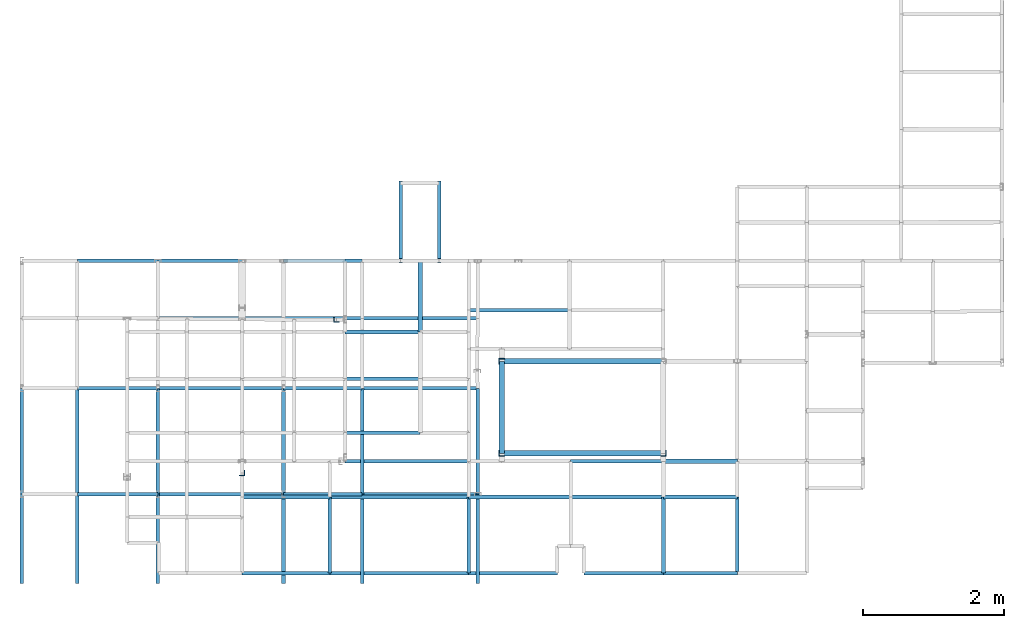
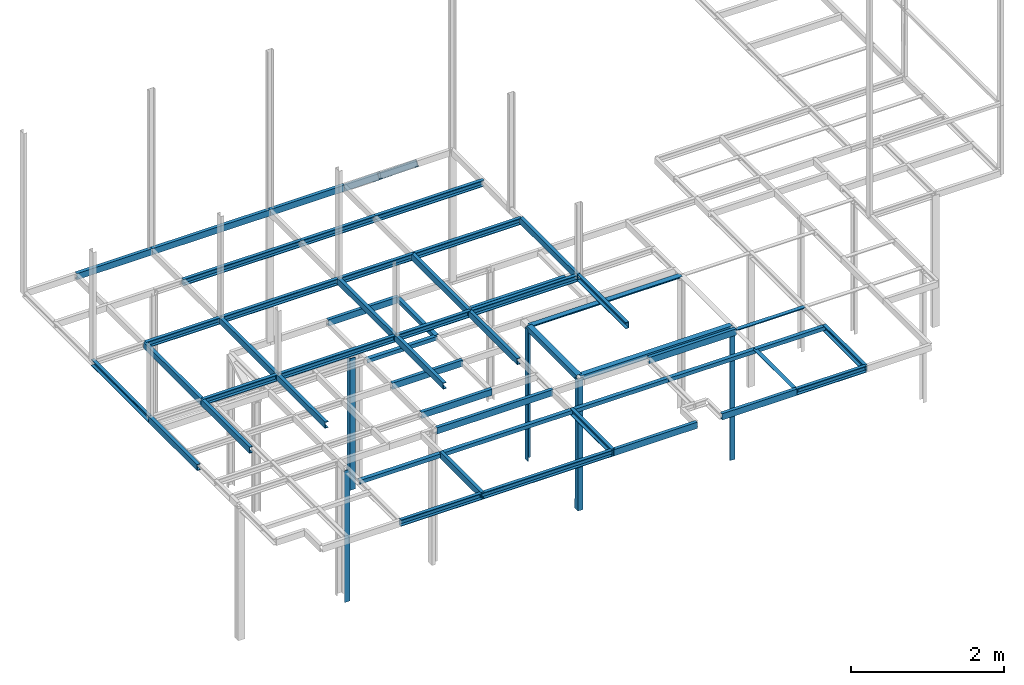
# Not in any storey, part 3 of 7: 52 beams, 7 members.
"""IFC2X3 model written with IfcOpenShell, lengths in centimetres."""

from ifc_helpers import new_model, si_unit, frame, frame_2d, origin_with_axes, origin_2d_with_axis, place, context, project, polyline, l_section, u_section, outline, extrude, material, element, save


model = new_model("IFC2X3")

# Units and contexts
model_context = context("Model", 3, precision=1e-05, world=origin_with_axes())
plan_context = context("Plan", 3, precision=1e-05, world=origin_with_axes())
ifc_project = project(units=[si_unit("LENGTHUNIT", "METRE", prefix="CENTI"), si_unit("AREAUNIT", "SQUARE_METRE", prefix="CENTI"), si_unit("VOLUMEUNIT", "CUBIC_METRE", prefix="CENTI"), si_unit("PLANEANGLEUNIT", "RADIAN"), si_unit("SOLIDANGLEUNIT", "STERADIAN"), si_unit("MASSUNIT", "GRAM"), si_unit("TIMEUNIT", "SECOND"), si_unit("THERMODYNAMICTEMPERATUREUNIT", "DEGREE_CELSIUS"), si_unit("LUMINOUSINTENSITYUNIT", "LUMEN")], contexts=[model_context, plan_context])

# Members
ifc_material = material()
for number, where, z_axis, x_axis in (
    (1, (-455.200012207031, 191.800003051758, 0.0), (0.0, 0.0, 1.0), (1.0, 0.0, 0.0)),
    (2, (-221.0, 132.699996948242, 0.0), (0.0, 0.0, 1.0), (0.0, -1.0, 0.0)),
):
    element("IfcMember", number, at=place(None, frame(where, z_axis=z_axis, x_axis=x_axis)), material=ifc_material, context=model_context, shape_type="SweptSolid", body=[
        extrude(l_section(Depth=8.0, Width=8.0, Thickness=0.8, FilletRadius=1.0, EdgeRadius=0.0, LegSlope=0.0, CentreOfGravityInX=0.0, CentreOfGravityInY=0.0, at=origin_2d_with_axis()), origin_with_axes(), (0.0, 0.0, 1.0), 210.0),
    ])
member_1_placement = place(None, frame((-221.199996948242, 2.299999952316, 0.0), z_axis=(0.000952365988, 0.0, 0.999999546499), x_axis=(0.999999523163, 0.0, -0.000952365983)))
element("IfcMember", 3, at=member_1_placement, material=ifc_material, context=model_context, shape_type="SweptSolid", body=[
    extrude(l_section(Depth=8.0, Width=8.0, Thickness=0.8, FilletRadius=1.0, EdgeRadius=0.0, LegSlope=0.0, CentreOfGravityInX=0.0, CentreOfGravityInY=0.0, at=frame_2d((0.0, -1.19209e-07), x_axis=(1.0, 0.0))), origin_with_axes(), (0.0, 0.0, 1.0), 210.000095235167),
])
member_2_placement = place(None, frame((8.199999809265, 2.299999952316, 0.0), z_axis=(0.0, 0.0, 1.0), x_axis=(0.0, 1.0, 0.0)))
element("IfcMember", 4, at=member_2_placement, material=ifc_material, context=model_context, shape_type="SweptSolid", body=[
    extrude(l_section(Depth=8.0, Width=8.0, Thickness=0.8, FilletRadius=1.0, EdgeRadius=0.0, LegSlope=0.0, CentreOfGravityInX=0.0, CentreOfGravityInY=0.0, at=frame_2d((-3.57628e-07, -2.38419e-07), x_axis=(1.0, 0.0))), origin_with_axes(), (0.0, 0.0, 1.0), 210.0),
])
member_3_placement = place(None, frame((-589.100036621094, -25.700000762939, 0.0), z_axis=(0.0, 0.0, 1.0), x_axis=(0.0, 1.0, 0.0)))
element("IfcMember", 5, at=member_3_placement, material=ifc_material, context=model_context, shape_type="SweptSolid", body=[
    extrude(l_section(Depth=8.0, Width=8.0, Thickness=0.8, FilletRadius=1.0, EdgeRadius=0.0, LegSlope=0.0, CentreOfGravityInX=0.0, CentreOfGravityInY=0.0, at=origin_2d_with_axis()), origin_with_axes(), (0.0, 0.0, 1.0), 210.0),
])

# Beams
beam_1_placement = place(None, frame((-336.600006103516, 275.0, 210.0), z_axis=(-1.0, 0.0, 0.0), x_axis=(0.0, 1.0, 0.0)))
element("IfcBeam", 6, at=beam_1_placement, material=ifc_material, Name="UPN - de ala UPN 100", context=model_context, shape_type="SweptSolid", body=[
    extrude(u_section(Depth=10.0, FlangeWidth=5.0, WebThickness=0.6, FlangeThickness=0.85, FilletRadius=0.0, EdgeRadius=0.0, FlangeSlope=0.0, CentreOfGravityInX=0.0, at=origin_2d_with_axis()), origin_with_axes(), (0.0, 0.0, 1.0), 106.5),
])
beam_2_placement = place(None, frame((-336.600006103516, 174.400009155273, 210.0), z_axis=(0.0, 1.0, 0.0), x_axis=(-1.0, 0.0, 0.0)))
element("IfcBeam", 7, at=beam_2_placement, material=ifc_material, context=model_context, shape_type="SweptSolid", body=[
    extrude(outline(polyline([(3.0, -3.0), (3.0, 3.0), (-3.0, 3.0), (-3.0, 2.5), (2.5, 2.5), (2.5, -3.0), (3.0, -3.0)])), origin_with_axes(), (0.0, 0.0, 1.0), 100.599990844727),
])
beam_3_placement = place(None, frame((-124.899993896484, 205.199996948242, 210.0), z_axis=(-1.0, 0.0, 0.0), x_axis=(0.0, 1.0, 0.0)))
element("IfcBeam", 8, at=beam_3_placement, material=ifc_material, Name="UPN - de ala UPN 100", context=model_context, shape_type="SweptSolid", body=[
    extrude(u_section(Depth=10.0, FlangeWidth=5.0, WebThickness=0.6, FlangeThickness=0.85, FilletRadius=0.0, EdgeRadius=0.0, FlangeSlope=0.0, CentreOfGravityInX=0.0, at=origin_2d_with_axis()), origin_with_axes(), (0.0, 0.0, 1.0), 143.100006103516),
])
beam_4_placement = place(None, frame((-336.600006103516, 174.400009155273, 210.0), z_axis=(-1.0, 0.0, 0.0), x_axis=(0.0, -1.0, 0.0)))
element("IfcBeam", 9, at=beam_4_placement, material=ifc_material, context=model_context, shape_type="SweptSolid", body=[
    extrude(outline(polyline([(3.0, -3.0), (3.0, 3.0), (-3.0, 3.0), (-3.0, 2.5), (2.5, 2.5), (2.5, -3.0), (3.0, -3.0)])), origin_with_axes(), (0.0, 0.0, 1.0), 106.5),
])
beam_5_placement = place(None, frame((8.199996948242, 132.699996948242, 210.0), z_axis=(-1.0, 0.0, 0.0), x_axis=(0.0, 0.0, 1.0)))
element("IfcBeam", 10, at=beam_5_placement, material=ifc_material, context=model_context, shape_type="SweptSolid", body=[
    extrude(outline(polyline([(4.0, -4.0), (4.0, 4.0), (-4.0, 4.0), (-4.0, 3.199996948242), (3.199996948242, 3.199996948242), (3.199996948242, -4.0), (4.0, -4.0)])), origin_with_axes(), (0.0, 0.0, 1.0), 229.199996948242),
])
beam_6_placement = place(None, frame((-221.0, 2.300003051758, 210.0), z_axis=(0.0, 1.0, 0.0), x_axis=(-1.0, 0.0, 0.0)))
element("IfcBeam", 11, at=beam_6_placement, material=ifc_material, context=model_context, shape_type="SweptSolid", body=[
    extrude(outline(polyline([(4.0, -4.0), (4.0, 4.0), (-4.0, 4.0), (-4.0, 3.199996948242), (3.199996948242, 3.199996948242), (3.199996948242, -4.0), (4.0, -4.0)])), origin_with_axes(), (0.0, 0.0, 1.0), 130.399993896484),
])
beam_7_placement = place(None, frame((-336.600006103516, 108.200004577637, 210.0), z_axis=(-1.0, 0.0, 0.0), x_axis=(0.0, 1.0, 0.0)))
element("IfcBeam", 12, at=beam_7_placement, material=ifc_material, Name="UPN - de ala UPN 100", context=model_context, shape_type="SweptSolid", body=[
    extrude(u_section(Depth=10.0, FlangeWidth=5.0, WebThickness=0.6, FlangeThickness=0.85, FilletRadius=0.0, EdgeRadius=0.0, FlangeSlope=0.0, CentreOfGravityInX=0.0, at=origin_2d_with_axis()), origin_with_axes(), (0.0, 0.0, 1.0), 106.5),
])
beam_8_placement = place(None, frame((-336.600006103516, 31.60000038147, 210.0), z_axis=(-1.0, 0.0, 0.0), x_axis=(0.0, 1.0, 0.0)))
element("IfcBeam", 13, at=beam_8_placement, material=ifc_material, Name="UPN - de ala UPN 100", context=model_context, shape_type="SweptSolid", body=[
    extrude(u_section(Depth=10.0, FlangeWidth=5.0, WebThickness=0.6, FlangeThickness=0.85, FilletRadius=0.0, EdgeRadius=0.0, FlangeSlope=0.0, CentreOfGravityInX=0.0, at=frame_2d((9.53674e-07, 0.0), x_axis=(1.0, 0.0))), origin_with_axes(), (0.0, 0.0, 1.0), 106.5),
])
beam_9_placement = place(None, frame((8.199996948242, 2.299999952316, 210.0), z_axis=(-1.0, 0.0, 0.0), x_axis=(0.0, -1.0, 0.0)))
element("IfcBeam", 14, at=beam_9_placement, material=ifc_material, context=model_context, shape_type="SweptSolid", body=[
    extrude(outline(polyline([(4.000000476837, -4.0), (3.999999284744, 4.0), (-4.000000238419, 4.0), (-4.000000238419, 3.199996948242), (3.199999570847, 3.199996948242), (3.200000762939, -4.0), (4.000000476837, -4.0)])), origin_with_axes(), (0.0, 0.0, 1.0), 229.199996948242),
])
beam_10_placement = place(None, frame((-268.0, -9.0, 210.0), z_axis=(-1.0, 0.0, 0.0), x_axis=(0.0, 1.0, 0.0)))
element("IfcBeam", 15, at=beam_10_placement, material=ifc_material, Name="UPN - de ala UPN 100", context=model_context, shape_type="SweptSolid", body=[
    extrude(u_section(Depth=10.0, FlangeWidth=5.0, WebThickness=0.6, FlangeThickness=0.85, FilletRadius=0.0, EdgeRadius=0.0, FlangeSlope=0.0, CentreOfGravityInX=0.0, at=frame_2d((2.38419e-07, 0.0), x_axis=(1.0, 0.0))), origin_with_axes(), (0.0, 0.0, 1.0), 175.0),
])
beam_11_placement = place(None, frame((8.199996948242, -9.0, 210.0), z_axis=(-1.0, 0.0, 0.0), x_axis=(0.0, 1.0, 0.0)))
element("IfcBeam", 16, at=beam_11_placement, material=ifc_material, Name="UPN - de ala UPN 100", context=model_context, shape_type="SweptSolid", body=[
    extrude(u_section(Depth=10.0, FlangeWidth=5.0, WebThickness=0.6, FlangeThickness=0.85, FilletRadius=0.0, EdgeRadius=0.0, FlangeSlope=0.0, CentreOfGravityInX=0.0, at=frame_2d((2.38419e-07, 0.0), x_axis=(1.0, 0.0))), origin_with_axes(), (0.0, 0.0, 1.0), 131.5),
])
beam_12_placement = place(None, frame((113.100001335144, -9.0, 210.0), z_axis=(-1.0, 0.0, 0.0), x_axis=(0.0, 0.0, 1.0)))
element("IfcBeam", 17, at=beam_12_placement, material=ifc_material, context=model_context, shape_type="SweptSolid", body=[
    extrude(outline(polyline([(3.0, -3.0), (3.0, 3.0), (-3.0, 3.0), (-3.0, 2.5), (2.5, 2.5), (2.5, -3.0), (3.0, -3.0)])), origin_with_axes(), (0.0, 0.0, 1.0), 104.900001525879),
])
beam_13_placement = place(None, frame((-464.600006103516, -59.600002288818, 210.0), z_axis=(-1.0, 0.0, 0.0), x_axis=(0.0, -1.0, 0.0)))
element("IfcBeam", 18, at=beam_13_placement, material=ifc_material, context=model_context, shape_type="SweptSolid", body=[
    extrude(outline(polyline([(3.0, -3.0), (3.0, 3.0), (-3.0, 3.0), (-3.0, 2.5), (2.5, 2.5), (2.5, -3.0), (3.0, -3.0)])), origin_with_axes(), (0.0, 0.0, 1.0), 124.500030517578),
])
beam_14_placement = place(None, frame((-268.0, -59.600002288818, 210.0), z_axis=(-1.0, 0.0, 0.0), x_axis=(0.0, -1.0, 0.0)))
element("IfcBeam", 19, at=beam_14_placement, material=ifc_material, context=model_context, shape_type="SweptSolid", body=[
    extrude(outline(polyline([(3.0, -3.0), (3.0, 3.0), (-3.0, 3.0), (-3.0, 2.5), (2.5, 2.5), (2.5, -3.0), (3.0, -3.0)])), origin_with_axes(), (0.0, 0.0, 1.0), 196.600006103516),
])
beam_15_placement = place(None, frame((-464.600006103516, -167.499996185303, 210.0), z_axis=(0.0, 1.0, 0.0), x_axis=(1.0, 0.0, 0.0)))
element("IfcBeam", 20, at=beam_15_placement, material=ifc_material, Name="UPN - de ala UPN 100", context=model_context, shape_type="SweptSolid", body=[
    extrude(u_section(Depth=10.0, FlangeWidth=5.0, WebThickness=0.6, FlangeThickness=0.85, FilletRadius=0.0, EdgeRadius=0.0, FlangeSlope=0.0, CentreOfGravityInX=0.0, at=origin_2d_with_axis()), origin_with_axes(), (0.0, 0.0, 1.0), 107.899993896484),
])
beam_16_placement = place(None, frame((-123.300003051758, -59.600002288818, 210.0), z_axis=(-1.0, 0.0, 0.0), x_axis=(0.0, -1.0, 0.0)))
element("IfcBeam", 21, at=beam_16_placement, material=ifc_material, context=model_context, shape_type="SweptSolid", body=[
    extrude(outline(polyline([(3.0, -3.0), (3.0, 3.0), (-3.0, 3.0), (-3.0, 2.5), (2.5, 2.5), (2.5, -3.0), (3.0, -3.0)])), origin_with_axes(), (0.0, 0.0, 1.0), 144.699996948242),
])
beam_17_placement = place(None, frame((-268.0, -167.499996185303, 210.0), z_axis=(0.0, 1.0, 0.0), x_axis=(-1.0, 0.0, 0.0)))
element("IfcBeam", 22, at=beam_17_placement, material=ifc_material, Name="UPN - de ala UPN 100", context=model_context, shape_type="SweptSolid", body=[
    extrude(u_section(Depth=10.0, FlangeWidth=5.0, WebThickness=0.6, FlangeThickness=0.85, FilletRadius=0.0, EdgeRadius=0.0, FlangeSlope=0.0, CentreOfGravityInX=0.0, at=origin_2d_with_axis()), origin_with_axes(), (0.0, 0.0, 1.0), 107.899993896484),
])
beam_18_placement = place(None, frame((8.199996948242, -59.600002288818, 210.0), z_axis=(-1.0, 0.0, 0.0), x_axis=(0.0, 0.0, -1.0)))
element("IfcBeam", 23, at=beam_18_placement, material=ifc_material, context=model_context, shape_type="SweptSolid", body=[
    extrude(outline(polyline([(-3.0, -3.0), (-2.5, -3.0), (-2.5, 2.5), (3.0, 2.5), (3.0, 3.0), (-3.0, 3.0), (-3.0, -3.0)])), origin_with_axes(), (0.0, 0.0, 1.0), 131.5),
])
beam_19_placement = place(None, frame((113.100001335144, -59.600002288818, 210.0), z_axis=(-1.0, 0.0, 0.0), x_axis=(0.0, -1.0, 0.0)))
element("IfcBeam", 24, at=beam_19_placement, material=ifc_material, context=model_context, shape_type="SweptSolid", body=[
    extrude(outline(polyline([(3.0, -3.0), (3.0, 3.0), (-3.0, 3.0), (-3.0, 2.5), (2.5, 2.5), (2.5, -3.0), (3.0, -3.0)])), origin_with_axes(), (0.0, 0.0, 1.0), 104.900001525879),
])
beam_20_placement = place(None, frame((8.199999809265, -167.499996185303, 210.0), z_axis=(0.0, 1.0, 0.0), x_axis=(-1.0, 0.0, 0.0)))
element("IfcBeam", 25, at=beam_20_placement, material=ifc_material, context=model_context, shape_type="SweptSolid", body=[
    extrude(outline(polyline([(-3.0, -3.0), (-2.5, -3.0), (-2.5, 2.5), (3.0, 2.5), (3.0, 3.0), (-3.0, 3.0), (-3.0, -3.0)])), origin_with_axes(), (0.0, 0.0, 1.0), 107.899993896484),
])
beam_21_placement = place(None, frame((113.099998474121, -167.499996185303, 210.0), z_axis=(0.0, 1.0, 0.0), x_axis=(-1.0, 0.0, 0.0)))
element("IfcBeam", 26, at=beam_21_placement, material=ifc_material, Name="UPN - de ala UPN 100", context=model_context, shape_type="SweptSolid", body=[
    extrude(u_section(Depth=10.0, FlangeWidth=5.0, WebThickness=0.6, FlangeThickness=0.85, FilletRadius=0.0, EdgeRadius=0.0, FlangeSlope=0.0, CentreOfGravityInX=0.0, at=origin_2d_with_axis()), origin_with_axes(), (0.0, 0.0, 1.0), 107.899993896484),
])
beam_22_placement = place(None, frame((-464.600006103516, -167.5, 210.0), z_axis=(-1.0, 0.0, 0.0), x_axis=(0.0, -1.0, 0.0)))
element("IfcBeam", 27, at=beam_22_placement, material=ifc_material, Name="UPN - de ala UPN 100", context=model_context, shape_type="SweptSolid", body=[
    extrude(u_section(Depth=10.0, FlangeWidth=5.0, WebThickness=0.6, FlangeThickness=0.85, FilletRadius=0.0, EdgeRadius=0.0, FlangeSlope=0.0, CentreOfGravityInX=0.0, at=origin_2d_with_axis()), origin_with_axes(), (0.0, 0.0, 1.0), 124.500030517578),
])
beam_23_placement = place(None, frame((-268.0, -167.5, 210.0), z_axis=(-1.0, 0.0, 0.0), x_axis=(0.0, -1.0, 0.0)))
element("IfcBeam", 28, at=beam_23_placement, material=ifc_material, Name="UPN - de ala UPN 100", context=model_context, shape_type="SweptSolid", body=[
    extrude(u_section(Depth=10.0, FlangeWidth=5.0, WebThickness=0.6, FlangeThickness=0.85, FilletRadius=0.0, EdgeRadius=0.0, FlangeSlope=0.0, CentreOfGravityInX=0.0, at=origin_2d_with_axis()), origin_with_axes(), (0.0, 0.0, 1.0), 196.600006103516),
])
beam_24_placement = place(None, frame((-142.0, -167.5, 210.0), z_axis=(-1.0, 0.0, 0.0), x_axis=(0.0, 1.0, 0.0)))
element("IfcBeam", 29, at=beam_24_placement, material=ifc_material, Name="UPN - de ala UPN 100", context=model_context, shape_type="SweptSolid", body=[
    extrude(u_section(Depth=10.0, FlangeWidth=5.0, WebThickness=0.6, FlangeThickness=0.85, FilletRadius=0.0, EdgeRadius=0.0, FlangeSlope=0.0, CentreOfGravityInX=0.0, at=origin_2d_with_axis()), origin_with_axes(), (0.0, 0.0, 1.0), 126.0),
])
beam_25_placement = place(None, frame((8.199996948242, -167.5, 210.0), z_axis=(-1.0, 0.0, 0.0), x_axis=(0.0, 1.0, 0.0)))
element("IfcBeam", 30, at=beam_25_placement, material=ifc_material, Name="UPN - de ala UPN 100", context=model_context, shape_type="SweptSolid", body=[
    extrude(u_section(Depth=10.0, FlangeWidth=5.0, WebThickness=0.6, FlangeThickness=0.85, FilletRadius=0.0, EdgeRadius=0.0, FlangeSlope=0.0, CentreOfGravityInX=0.0, at=origin_2d_with_axis()), origin_with_axes(), (0.0, 0.0, 1.0), 112.799995422363),
])
beam_26_placement = place(None, frame((113.100001335144, -167.5, 210.0), z_axis=(-1.0, 0.0, 0.0), x_axis=(0.0, -1.0, 0.0)))
element("IfcBeam", 31, at=beam_26_placement, material=ifc_material, Name="UPN - de ala UPN 100", context=model_context, shape_type="SweptSolid", body=[
    extrude(u_section(Depth=10.0, FlangeWidth=5.0, WebThickness=0.6, FlangeThickness=0.85, FilletRadius=0.0, EdgeRadius=0.0, FlangeSlope=0.0, CentreOfGravityInX=0.0, at=origin_2d_with_axis()), origin_with_axes(), (0.0, 0.0, 1.0), 104.900001525879),
])

# Members
for number, where, z_axis, x_axis, name in (
    (32, (-364.200012207031, 385.0, 326.5), (0.0, -0.773957299203, 0.633237790257), (1.0, 0.0, 0.0), "UPN - de ala UPN 100"),
    (33, (-309.600006103516, 385.0, 326.5), (0.0, -0.773957299203, 0.633237790257), (-1.0, 0.0, 0.0), "UPN - de ala UPN 100"),
):
    element("IfcMember", number, at=place(None, frame(where, z_axis=z_axis, x_axis=x_axis)), material=ifc_material, Name=name, context=model_context, shape_type="SweptSolid", body=[
        extrude(u_section(Depth=10.0, FlangeWidth=5.0, WebThickness=0.6, FlangeThickness=0.85, FilletRadius=0.0, EdgeRadius=0.0, FlangeSlope=0.0, CentreOfGravityInX=0.0, at=origin_2d_with_axis()), origin_with_axes(), (0.0, 0.0, 1.0), 142.126704035519),
    ])

# Beams
beam_27_placement = place(None, frame((-708.5, 275.0, 416.5), z_axis=(-1.0, 0.0, 0.0), x_axis=(0.0, 1.0, 0.0)))
element("IfcBeam", 34, at=beam_27_placement, material=ifc_material, Name="UPN - de ala UPN 100", context=model_context, shape_type="SweptSolid", body=[
    extrude(u_section(Depth=10.0, FlangeWidth=5.0, WebThickness=0.6, FlangeThickness=0.85, FilletRadius=0.0, EdgeRadius=0.0, FlangeSlope=0.0, CentreOfGravityInX=0.0, at=origin_2d_with_axis()), origin_with_axes(), (0.0, 0.0, 1.0), 113.900024414062),
])
beam_28_placement = place(None, frame((-530.299987792969, 275.0, 416.5), z_axis=(-1.0, 0.0, 0.0), x_axis=(0.0, 1.0, 0.0)))
element("IfcBeam", 35, at=beam_28_placement, material=ifc_material, Name="UPN - de ala UPN 100", context=model_context, shape_type="SweptSolid", body=[
    extrude(u_section(Depth=10.0, FlangeWidth=5.0, WebThickness=0.6, FlangeThickness=0.85, FilletRadius=0.0, EdgeRadius=0.0, FlangeSlope=0.0, CentreOfGravityInX=0.0, at=origin_2d_with_axis()), origin_with_axes(), (0.0, 0.0, 1.0), 178.200012207031),
])
beam_29_placement = place(None, frame((-418.800018310547, 275.0, 416.5), z_axis=(-1.0, 0.0, 0.0), x_axis=(0.0, 1.0, 0.0)))
element("IfcBeam", 36, at=beam_29_placement, material=ifc_material, Name="UPN - de ala UPN 100", context=model_context, shape_type="SweptSolid", body=[
    extrude(u_section(Depth=10.0, FlangeWidth=5.0, WebThickness=0.6, FlangeThickness=0.85, FilletRadius=0.0, EdgeRadius=0.0, FlangeSlope=0.0, CentreOfGravityInX=0.0, at=origin_2d_with_axis()), origin_with_axes(), (0.0, 0.0, 1.0), 111.499969482422),
])
beam_30_placement = place(None, frame((-530.299987792969, 193.5, 416.5), z_axis=(-1.0, 0.0, 0.0), x_axis=(0.0, -1.0, 0.0)))
element("IfcBeam", 37, at=beam_30_placement, material=ifc_material, Name="UPN - de ala UPN 100", context=model_context, shape_type="SweptSolid", body=[
    extrude(u_section(Depth=10.0, FlangeWidth=5.0, WebThickness=0.6, FlangeThickness=0.85, FilletRadius=0.0, EdgeRadius=0.0, FlangeSlope=0.0, CentreOfGravityInX=0.0, at=origin_2d_with_axis()), origin_with_axes(), (0.0, 0.0, 1.0), 178.200012207031),
])
beam_31_placement = place(None, frame((-418.800018310547, 193.5, 416.5), z_axis=(-1.0, 0.0, 0.0), x_axis=(0.0, -1.0, 0.0)))
element("IfcBeam", 38, at=beam_31_placement, material=ifc_material, Name="UPN - de ala UPN 100", context=model_context, shape_type="SweptSolid", body=[
    extrude(u_section(Depth=10.0, FlangeWidth=5.0, WebThickness=0.6, FlangeThickness=0.85, FilletRadius=0.0, EdgeRadius=0.0, FlangeSlope=0.0, CentreOfGravityInX=0.0, at=origin_2d_with_axis()), origin_with_axes(), (0.0, 0.0, 1.0), 111.499969482422),
])
beam_32_placement = place(None, frame((-255.0, 193.5, 416.5), z_axis=(-1.0, 0.0, 0.0), x_axis=(0.0, -1.0, 0.0)))
element("IfcBeam", 39, at=beam_32_placement, material=ifc_material, Name="UPN - de ala UPN 100", context=model_context, shape_type="SweptSolid", body=[
    extrude(u_section(Depth=10.0, FlangeWidth=5.0, WebThickness=0.6, FlangeThickness=0.85, FilletRadius=0.0, EdgeRadius=0.0, FlangeSlope=0.0, CentreOfGravityInX=0.0, at=origin_2d_with_axis()), origin_with_axes(), (0.0, 0.0, 1.0), 163.800018310547),
])
beam_33_placement = place(None, frame((-901.299987792969, -55.500007629395, 416.5), z_axis=(0.0, 1.0, 0.0), x_axis=(-1.0, 0.0, 0.0)))
element("IfcBeam", 40, at=beam_33_placement, material=ifc_material, Name="UPN - de ala UPN 100", context=model_context, shape_type="SweptSolid", body=[
    extrude(u_section(Depth=10.0, FlangeWidth=5.0, WebThickness=0.6, FlangeThickness=0.85, FilletRadius=0.0, EdgeRadius=0.0, FlangeSlope=0.0, CentreOfGravityInX=0.0, at=origin_2d_with_axis()), origin_with_axes(), (0.0, 0.0, 1.0), 149.700012207031),
])
beam_34_placement = place(None, frame((-708.5, 94.200004577637, 416.5), z_axis=(-1.0, 0.0, 0.0), x_axis=(0.0, -1.0, 0.0)))
element("IfcBeam", 41, at=beam_34_placement, material=ifc_material, Name="UPN - de ala UPN 100", context=model_context, shape_type="SweptSolid", body=[
    extrude(u_section(Depth=10.0, FlangeWidth=5.0, WebThickness=0.6, FlangeThickness=0.85, FilletRadius=0.0, EdgeRadius=0.0, FlangeSlope=0.0, CentreOfGravityInX=0.0, at=origin_2d_with_axis()), origin_with_axes(), (0.0, 0.0, 1.0), 113.900024414062),
])
beam_35_placement = place(None, frame((-822.400024414062, -55.500007629395, 416.5), z_axis=(0.0, 1.0, 0.0), x_axis=(1.0, 0.0, 0.0)))
element("IfcBeam", 42, at=beam_35_placement, material=ifc_material, Name="UPN - de ala UPN 100", context=model_context, shape_type="SweptSolid", body=[
    extrude(u_section(Depth=10.0, FlangeWidth=5.0, WebThickness=0.6, FlangeThickness=0.85, FilletRadius=0.0, EdgeRadius=0.0, FlangeSlope=0.0, CentreOfGravityInX=0.0, at=origin_2d_with_axis()), origin_with_axes(), (0.0, 0.0, 1.0), 149.700012207031),
])
beam_36_placement = place(None, frame((-530.299987792969, 94.200004577637, 416.5), z_axis=(-1.0, 0.0, 0.0), x_axis=(0.0, -1.0, 0.0)))
element("IfcBeam", 43, at=beam_36_placement, material=ifc_material, Name="UPN - de ala UPN 100", context=model_context, shape_type="SweptSolid", body=[
    extrude(u_section(Depth=10.0, FlangeWidth=5.0, WebThickness=0.6, FlangeThickness=0.85, FilletRadius=0.0, EdgeRadius=0.0, FlangeSlope=0.0, CentreOfGravityInX=0.0, at=origin_2d_with_axis()), origin_with_axes(), (0.0, 0.0, 1.0), 178.200012207031),
])
beam_37_placement = place(None, frame((-708.5, -55.500007629395, 416.5), z_axis=(0.0, 1.0, 0.0), x_axis=(1.0, 0.0, 0.0)))
element("IfcBeam", 44, at=beam_37_placement, material=ifc_material, Name="UPN - de ala UPN 100", context=model_context, shape_type="SweptSolid", body=[
    extrude(u_section(Depth=10.0, FlangeWidth=5.0, WebThickness=0.6, FlangeThickness=0.85, FilletRadius=0.0, EdgeRadius=0.0, FlangeSlope=0.0, CentreOfGravityInX=0.0, at=origin_2d_with_axis()), origin_with_axes(), (0.0, 0.0, 1.0), 149.700012207031),
])
beam_38_placement = place(None, frame((-418.800018310547, 94.200004577637, 416.5), z_axis=(-1.0, 0.0, 0.0), x_axis=(0.0, -1.0, 0.0)))
element("IfcBeam", 45, at=beam_38_placement, material=ifc_material, Name="UPN - de ala UPN 100", context=model_context, shape_type="SweptSolid", body=[
    extrude(u_section(Depth=10.0, FlangeWidth=5.0, WebThickness=0.6, FlangeThickness=0.85, FilletRadius=0.0, EdgeRadius=0.0, FlangeSlope=0.0, CentreOfGravityInX=0.0, at=origin_2d_with_axis()), origin_with_axes(), (0.0, 0.0, 1.0), 111.499969482422),
])
beam_39_placement = place(None, frame((-530.299987792969, -55.500007629395, 416.5), z_axis=(0.0, 1.0, 0.0), x_axis=(1.0, 0.0, 0.0)))
element("IfcBeam", 46, at=beam_39_placement, material=ifc_material, Name="UPN - de ala UPN 100", context=model_context, shape_type="SweptSolid", body=[
    extrude(u_section(Depth=10.0, FlangeWidth=5.0, WebThickness=0.6, FlangeThickness=0.85, FilletRadius=0.0, EdgeRadius=0.0, FlangeSlope=0.0, CentreOfGravityInX=0.0, at=origin_2d_with_axis()), origin_with_axes(), (0.0, 0.0, 1.0), 149.700012207031),
])
beam_40_placement = place(None, frame((-255.0, 94.200004577637, 416.5), z_axis=(-1.0, 0.0, 0.0), x_axis=(0.0, -1.0, 0.0)))
element("IfcBeam", 47, at=beam_40_placement, material=ifc_material, Name="UPN - de ala UPN 100", context=model_context, shape_type="SweptSolid", body=[
    extrude(u_section(Depth=10.0, FlangeWidth=5.0, WebThickness=0.6, FlangeThickness=0.85, FilletRadius=0.0, EdgeRadius=0.0, FlangeSlope=0.0, CentreOfGravityInX=0.0, at=origin_2d_with_axis()), origin_with_axes(), (0.0, 0.0, 1.0), 163.800018310547),
])
for number, where, z_axis, x_axis, name in (
    (48, (-418.800018310547, -55.500007629395, 416.5), (0.0, 1.0, 0.0), (1.0, 0.0, 0.0), "UPN - de ala UPN 100"),
    (49, (-255.0, -55.500007629395, 416.5), (0.0, 1.0, 0.0), (1.0, 0.0, 0.0), "UPN - de ala UPN 100"),
):
    element("IfcBeam", number, at=place(None, frame(where, z_axis=z_axis, x_axis=x_axis)), material=ifc_material, Name=name, context=model_context, shape_type="SweptSolid", body=[
        extrude(u_section(Depth=10.0, FlangeWidth=5.0, WebThickness=0.6, FlangeThickness=0.85, FilletRadius=0.0, EdgeRadius=0.0, FlangeSlope=0.0, CentreOfGravityInX=0.0, at=origin_2d_with_axis()), origin_with_axes(), (0.0, 0.0, 1.0), 149.700012207031),
    ])
beam_41_placement = place(None, frame((-901.299987792969, -182.600006103516, 416.5), z_axis=(0.0, 1.0, 0.0), x_axis=(1.0, 0.0, 0.0)))
element("IfcBeam", 50, at=beam_41_placement, material=ifc_material, Name="UPN - de ala UPN 100", context=model_context, shape_type="SweptSolid", body=[
    extrude(u_section(Depth=10.0, FlangeWidth=5.0, WebThickness=0.6, FlangeThickness=0.85, FilletRadius=0.0, EdgeRadius=0.0, FlangeSlope=0.0, CentreOfGravityInX=0.0, at=origin_2d_with_axis()), origin_with_axes(), (0.0, 0.0, 1.0), 127.100006103516),
])
beam_42_placement = place(None, frame((-708.5, -55.5, 416.5), z_axis=(-1.0, 0.0, 0.0), x_axis=(0.0, -1.0, 0.0)))
element("IfcBeam", 51, at=beam_42_placement, material=ifc_material, Name="UPN - de ala UPN 100", context=model_context, shape_type="SweptSolid", body=[
    extrude(u_section(Depth=10.0, FlangeWidth=5.0, WebThickness=0.6, FlangeThickness=0.85, FilletRadius=0.0, EdgeRadius=0.0, FlangeSlope=0.0, CentreOfGravityInX=0.0, at=origin_2d_with_axis()), origin_with_axes(), (0.0, 0.0, 1.0), 113.900024414062),
])
beam_43_placement = place(None, frame((-822.400024414062, -182.600006103516, 416.5), z_axis=(0.0, 1.0, 0.0), x_axis=(1.0, 0.0, 0.0)))
element("IfcBeam", 52, at=beam_43_placement, material=ifc_material, Name="UPN - de ala UPN 100", context=model_context, shape_type="SweptSolid", body=[
    extrude(u_section(Depth=10.0, FlangeWidth=5.0, WebThickness=0.6, FlangeThickness=0.85, FilletRadius=0.0, EdgeRadius=0.0, FlangeSlope=0.0, CentreOfGravityInX=0.0, at=origin_2d_with_axis()), origin_with_axes(), (0.0, 0.0, 1.0), 127.100006103516),
])
beam_44_placement = place(None, frame((-530.299987792969, -55.5, 416.5), z_axis=(-1.0, 0.0, 0.0), x_axis=(0.0, -1.0, 0.0)))
element("IfcBeam", 53, at=beam_44_placement, material=ifc_material, Name="UPN - de ala UPN 100", context=model_context, shape_type="SweptSolid", body=[
    extrude(u_section(Depth=10.0, FlangeWidth=5.0, WebThickness=0.6, FlangeThickness=0.85, FilletRadius=0.0, EdgeRadius=0.0, FlangeSlope=0.0, CentreOfGravityInX=0.0, at=origin_2d_with_axis()), origin_with_axes(), (0.0, 0.0, 1.0), 178.200012207031),
])
beam_45_placement = place(None, frame((-708.5, -182.600006103516, 416.5), z_axis=(0.0, 1.0, 0.0), x_axis=(1.0, 0.0, 0.0)))
element("IfcBeam", 54, at=beam_45_placement, material=ifc_material, Name="UPN - de ala UPN 100", context=model_context, shape_type="SweptSolid", body=[
    extrude(u_section(Depth=10.0, FlangeWidth=5.0, WebThickness=0.6, FlangeThickness=0.85, FilletRadius=0.0, EdgeRadius=0.0, FlangeSlope=0.0, CentreOfGravityInX=0.0, at=origin_2d_with_axis()), origin_with_axes(), (0.0, 0.0, 1.0), 127.100006103516),
])
beam_46_placement = place(None, frame((-418.800018310547, -55.5, 416.5), z_axis=(-1.0, 0.0, 0.0), x_axis=(0.0, -1.0, 0.0)))
element("IfcBeam", 55, at=beam_46_placement, material=ifc_material, Name="UPN - de ala UPN 100", context=model_context, shape_type="SweptSolid", body=[
    extrude(u_section(Depth=10.0, FlangeWidth=5.0, WebThickness=0.6, FlangeThickness=0.85, FilletRadius=0.0, EdgeRadius=0.0, FlangeSlope=0.0, CentreOfGravityInX=0.0, at=origin_2d_with_axis()), origin_with_axes(), (0.0, 0.0, 1.0), 111.499969482422),
])
beam_47_placement = place(None, frame((-530.299987792969, -182.600006103516, 416.5), z_axis=(0.0, 1.0, 0.0), x_axis=(1.0, 0.0, 0.0)))
element("IfcBeam", 56, at=beam_47_placement, material=ifc_material, Name="UPN - de ala UPN 100", context=model_context, shape_type="SweptSolid", body=[
    extrude(u_section(Depth=10.0, FlangeWidth=5.0, WebThickness=0.6, FlangeThickness=0.85, FilletRadius=0.0, EdgeRadius=0.0, FlangeSlope=0.0, CentreOfGravityInX=0.0, at=origin_2d_with_axis()), origin_with_axes(), (0.0, 0.0, 1.0), 127.100006103516),
])
beam_48_placement = place(None, frame((-255.0, -55.5, 416.5), z_axis=(-1.0, 0.0, 0.0), x_axis=(0.0, -1.0, 0.0)))
element("IfcBeam", 57, at=beam_48_placement, material=ifc_material, Name="UPN - de ala UPN 100", context=model_context, shape_type="SweptSolid", body=[
    extrude(u_section(Depth=10.0, FlangeWidth=5.0, WebThickness=0.6, FlangeThickness=0.85, FilletRadius=0.0, EdgeRadius=0.0, FlangeSlope=0.0, CentreOfGravityInX=0.0, at=origin_2d_with_axis()), origin_with_axes(), (0.0, 0.0, 1.0), 163.800018310547),
])
for number, where, z_axis, x_axis, name in (
    (58, (-418.800018310547, -182.600006103516, 416.5), (0.0, 1.0, 0.0), (1.0, 0.0, 0.0), "UPN - de ala UPN 100"),
    (59, (-255.0, -182.600006103516, 416.5), (0.0, 1.0, 0.0), (-1.0, 0.0, 0.0), "UPN - de ala UPN 100"),
):
    element("IfcBeam", number, at=place(None, frame(where, z_axis=z_axis, x_axis=x_axis)), material=ifc_material, Name=name, context=model_context, shape_type="SweptSolid", body=[
        extrude(u_section(Depth=10.0, FlangeWidth=5.0, WebThickness=0.6, FlangeThickness=0.85, FilletRadius=0.0, EdgeRadius=0.0, FlangeSlope=0.0, CentreOfGravityInX=0.0, at=origin_2d_with_axis()), origin_with_axes(), (0.0, 0.0, 1.0), 127.100006103516),
    ])

save(model, "model.ifc")
